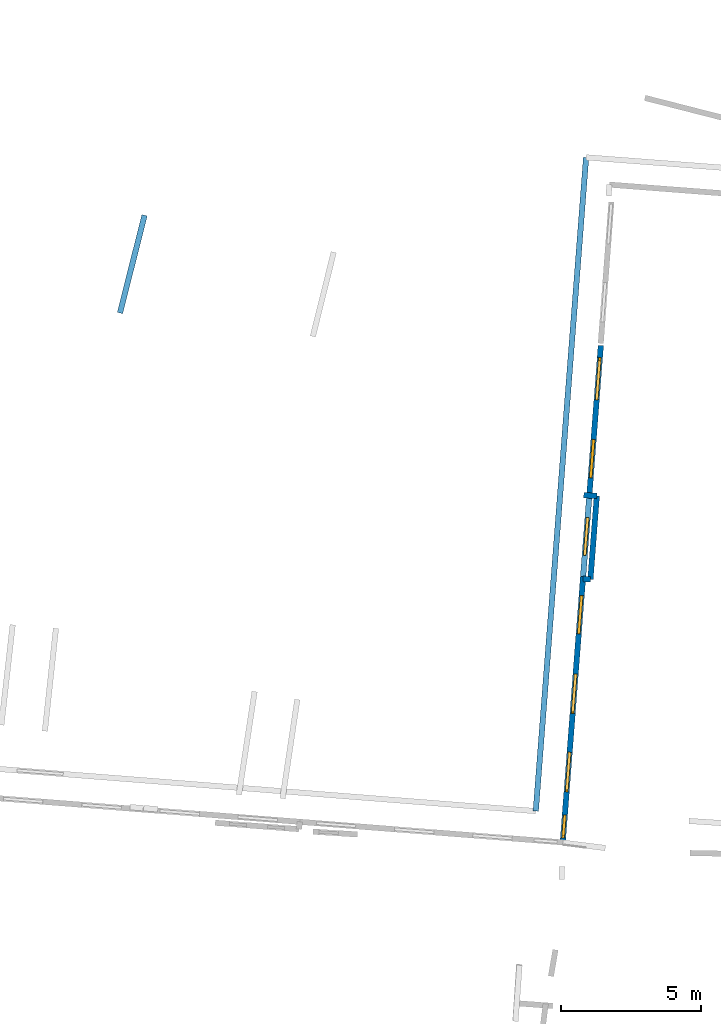
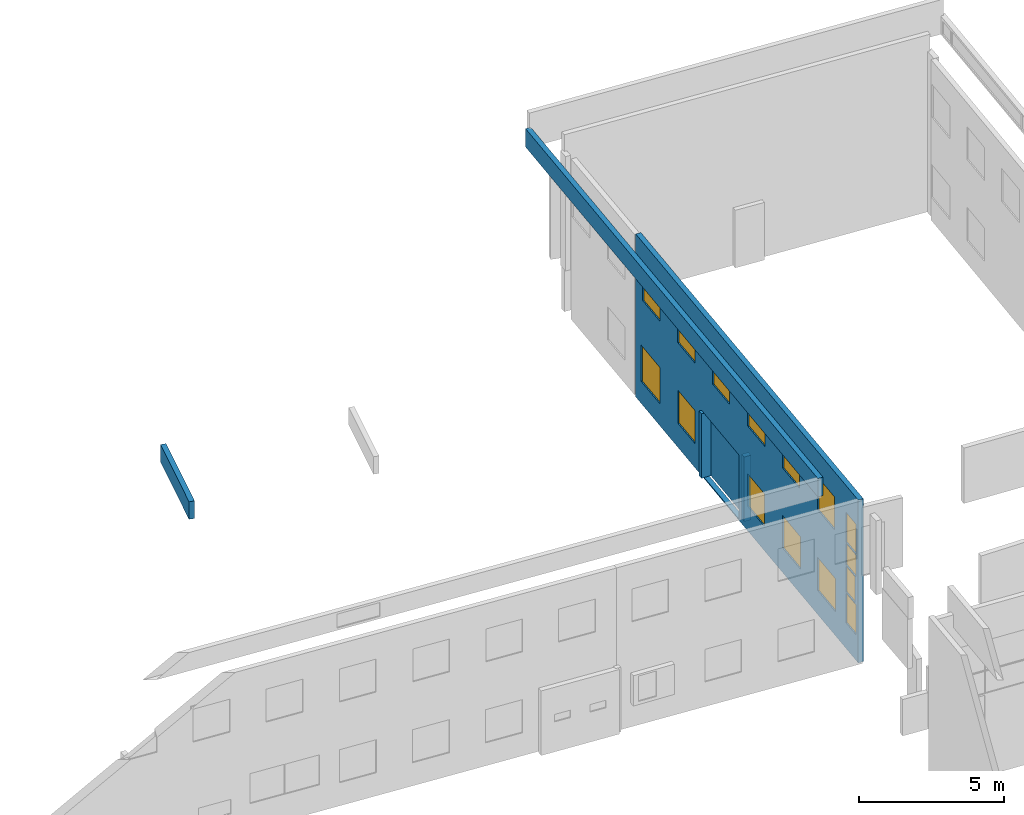
# One storey, part 22 of 27: 15 windows, 6 walls, 16 openings.
"""IFC2X3 building model written with IfcOpenShell, lengths in metres."""

from ifc_helpers import new_model, entity, si_unit, converted_unit, derived_unit, direction, frame, frame_2d, origin, origin_2d_with_axis, place, context, subcontext, project, spatial, polyline, rectangle, outline, extrude, source, transform, mapped, material, layer, layer_set, layer_usage, type_object, type_shapes, element, fill, save


model = new_model("IFC2X3")

# Units and contexts
model_context = context("Model", 3, precision=1e-05, world=origin(), true_north=direction((0.0, 1.0)))
body_context = subcontext(model_context, "Body", "Model", "MODEL_VIEW")
ifc_project = project(units=[si_unit("LENGTHUNIT", "METRE"), si_unit("AREAUNIT", "SQUARE_METRE"), si_unit("VOLUMEUNIT", "CUBIC_METRE"), converted_unit("PLANEANGLEUNIT", "DEGREE", entity("IfcRatioMeasure", 0.0174532925199433), si_unit("PLANEANGLEUNIT", "RADIAN"), dimensions=[0, 0, 0, 0, 0, 0, 0]), si_unit("MASSUNIT", "GRAM", prefix="KILO"), derived_unit("MASSDENSITYUNIT", [(si_unit("MASSUNIT", "GRAM", prefix="KILO"), 1), (si_unit("LENGTHUNIT", "METRE"), -3)]), derived_unit("MOMENTOFINERTIAUNIT", [(si_unit("LENGTHUNIT", "METRE"), 4)]), si_unit("TIMEUNIT", "SECOND"), si_unit("FREQUENCYUNIT", "HERTZ"), si_unit("THERMODYNAMICTEMPERATUREUNIT", "DEGREE_CELSIUS"), derived_unit("THERMALTRANSMITTANCEUNIT", [(si_unit("MASSUNIT", "GRAM", prefix="KILO"), 1), (si_unit("THERMODYNAMICTEMPERATUREUNIT", "KELVIN"), -1), (si_unit("TIMEUNIT", "SECOND"), -3)]), derived_unit("VOLUMETRICFLOWRATEUNIT", [(si_unit("LENGTHUNIT", "METRE"), 3), (si_unit("TIMEUNIT", "SECOND"), -1)]), si_unit("ELECTRICCURRENTUNIT", "AMPERE"), si_unit("ELECTRICVOLTAGEUNIT", "VOLT"), si_unit("POWERUNIT", "WATT"), si_unit("FORCEUNIT", "NEWTON", prefix="KILO"), si_unit("ILLUMINANCEUNIT", "LUX"), si_unit("LUMINOUSFLUXUNIT", "LUMEN"), si_unit("LUMINOUSINTENSITYUNIT", "CANDELA"), derived_unit("USERDEFINED", [(si_unit("MASSUNIT", "GRAM", prefix="KILO"), -1), (si_unit("LENGTHUNIT", "METRE"), -2), (si_unit("TIMEUNIT", "SECOND"), 3), (si_unit("LUMINOUSFLUXUNIT", "LUMEN"), 1)]), derived_unit("LINEARVELOCITYUNIT", [(si_unit("LENGTHUNIT", "METRE"), 1), (si_unit("TIMEUNIT", "SECOND"), -1)]), si_unit("PRESSUREUNIT", "PASCAL"), derived_unit("USERDEFINED", [(si_unit("LENGTHUNIT", "METRE"), -2), (si_unit("MASSUNIT", "GRAM", prefix="KILO"), 1), (si_unit("TIMEUNIT", "SECOND"), -2)]), derived_unit("LINEARFORCEUNIT", [(si_unit("MASSUNIT", "GRAM", prefix="KILO"), 1), (si_unit("LENGTHUNIT", "METRE"), 1), (si_unit("TIMEUNIT", "SECOND"), -2), (si_unit("LENGTHUNIT", "METRE"), -1)]), derived_unit("PLANARFORCEUNIT", [(si_unit("MASSUNIT", "GRAM", prefix="KILO"), 1), (si_unit("LENGTHUNIT", "METRE"), 1), (si_unit("TIMEUNIT", "SECOND"), -2), (si_unit("LENGTHUNIT", "METRE"), -2)])], contexts=[model_context])

# Site, building, storey
placement_1 = place(None, origin())
site = spatial("IfcSite", under=ifc_project, at=placement_1, CompositionType="ELEMENT")
building = spatial("IfcBuilding", under=site, at=placement_1, CompositionType="ELEMENT")
storey_placement = place(placement_1, frame((0.0, 0.0, -61.043098449707)))
storey = spatial("IfcBuildingStorey", under=building, at=storey_placement, Name="level_-61.043098", CompositionType="ELEMENT", Elevation=-61.043098449707)

# Walls
ifc_material_1 = material(Name="Default wall")
ifc_layer = layer(ifc_material_1, 0.2)
ifc_layer_set = layer_set([ifc_layer], Name="wall_thickness_0.2000")
ifc_layer_usage = layer_usage(ifc_layer_set, "AXIS2", "POSITIVE", -0.1)
wall_type = type_object("IfcWallType", Name="wall_thickness_0.2000", PredefinedType="STANDARD", material=ifc_layer_set)
wall_1_placement = place(storey_placement, frame((5.55051901657496, 6.89145809731428, 0.0), z_axis=(0.0, 0.0, 1.0), x_axis=(-0.0764744936915712, -0.997071537962356, 0.0)))
element("IfcWallStandardCase", 1, at=wall_1_placement, inside=storey, type_object=wall_type, material=ifc_layer_usage, Name="Wall:224", ObjectType="Wall", context=body_context, shape_type="SweptSolid", body=[
    extrude(outline(polyline([(2.98474913976987, -0.1), (2.98474913976987, 0.1), (0.0, 0.1), (0.0, -0.1), (2.98474913976987, -0.1)])), origin(), (0.0, 0.0, 1.0), 2.72571182250977),
])
wall_2_placement = place(storey_placement, frame((5.32226209215566, 3.91544977121613, 0.0), z_axis=(0.0, 0.0, 1.0), x_axis=(-0.997131622481555, 0.0756870361904948, 0.0)))
element("IfcWallStandardCase", 2, at=wall_2_placement, inside=storey, type_object=wall_type, material=ifc_layer_usage, Name="Wall:591", ObjectType="Wall", context=body_context, shape_type="SweptSolid", body=[
    extrude(outline(polyline([(0.268145565594101, -0.1), (0.268145565594101, 0.1), (0.0, 0.1), (0.0, -0.1), (0.268145565594101, -0.1)])), origin(), (0.0, 0.0, 1.0), 2.72571182250977),
])
placement_2 = place(placement_1, frame((0.0, 0.0, -54.4207000732422)))
wall_3_placement = place(placement_2, frame((3.37360948444382, -4.34450455838752, 0.0), z_axis=(0.0, 0.0, 1.0), x_axis=(0.0767496885314045, 0.99705039256315, 0.0)))
element("IfcWallStandardCase", 3, at=wall_3_placement, inside=storey, type_object=wall_type, material=ifc_layer_usage, Name="Wall:743", ObjectType="Wall", context=body_context, shape_type="SweptSolid", body=[
    extrude(outline(polyline([(23.3795139389043, -0.1), (23.3795139389043, 0.1), (0.0, 0.1), (0.0, -0.1), (23.3795139389043, -0.1)])), origin(), (0.0, 0.0, 1.0), 0.772296905517578),
])
placement_3 = place(placement_1, frame((0.0, 0.0, -60.9578857421875)))
wall_4_placement = place(placement_3, frame((-11.4522340122233, 13.4179110781104, 0.0), z_axis=(0.0, 0.0, 1.0), x_axis=(0.244021418068795, 0.969769842552188, 0.0)))
element("IfcWallStandardCase", 4, at=wall_4_placement, inside=storey, type_object=wall_type, material=ifc_layer_usage, Name="Wall:932", ObjectType="Wall", context=body_context, shape_type="SweptSolid", body=[
    extrude(outline(polyline([(3.59132385390913, -0.1), (3.59132385390913, 0.1), (0.0, 0.1), (0.0, -0.1), (3.59132385390913, -0.1)])), origin(), (0.0, 0.0, 1.0), 0.739894866943359),
])
wall_5_placement = place(storey_placement, frame((5.55051928604574, 6.89145879668962, 0.0), z_axis=(0.0, 0.0, 1.0), x_axis=(-0.997841850426368, 0.0656630911371277, 0.0)))
element("IfcWallStandardCase", 5, at=wall_5_placement, inside=storey, type_object=wall_type, material=ifc_layer_usage, Name="Wall:1461", ObjectType="Wall", context=body_context, shape_type="SweptSolid", body=[
    extrude(outline(polyline([(0.467316178286604, -0.1), (0.467316178286604, 0.1), (0.0, 0.1), (0.0, -0.1), (0.467316178286604, -0.1)])), origin(), (0.0, 0.0, 1.0), 2.72571182250977),
])

# Wall, openings, windows
placement_4 = place(placement_1, frame((0.0, 0.0, -61.0783157348633)))
wall_6_placement = place(placement_4, frame((5.69245260744282, 12.2572666512546, 0.0), z_axis=(0.0, 0.0, 1.0), x_axis=(-0.076392795427846, -0.997077800779217, 0.0)))
wall_6 = element("IfcWallStandardCase", 6, at=wall_6_placement, inside=storey, type_object=wall_type, material=ifc_layer_usage, Name="Wall:1689", ObjectType="Wall", context=body_context, shape_type="SweptSolid", body=[
    extrude(outline(polyline([(17.778165750979, -0.1), (17.778165750979, 0.1), (0.0, 0.1), (0.0, -0.1), (17.778165750979, -0.1)])), origin(), (0.0, 0.0, 1.0), 6.869140625),
])
opening_1_placement = place(wall_6_placement, frame((5.45000039480544, -0.1, 0.0490188598632812)))
element("IfcOpeningElement", 7, at=opening_1_placement, cuts=wall_6, Name="Opening : 2820 x 2705 : 268", ObjectType="Opening", context=body_context, shape_type="SweptSolid", body=[
    extrude(rectangle(XDim=2.82, YDim=2.705, at=frame_2d((1.3525, 1.41), x_axis=(0.0, 1.0))), frame((0.0, 0.0, 0.0), z_axis=(0.0, 1.0, 0.0), x_axis=(0.0, 0.0, 1.0)), (0.0, 0.0, 1.0), 0.2),
])
opening_2_placement = place(wall_6_placement, frame((0.545000040592521, -0.1, 4.40901947021484)))
opening_2 = element("IfcOpeningElement", 8, at=opening_2_placement, cuts=wall_6, Name="Opening : 1405 x 1395 : 269", ObjectType="Opening", context=body_context, shape_type="SweptSolid", body=[
    extrude(rectangle(XDim=1.405, YDim=1.395, at=frame_2d((0.6975, 0.7025), x_axis=(0.0, 1.0))), frame((0.0, 0.0, 0.0), z_axis=(0.0, 1.0, 0.0), x_axis=(0.0, 0.0, 1.0)), (0.0, 0.0, 1.0), 0.2),
])
opening_3_placement = place(wall_6_placement, frame((0.435350386967062, -0.1, 0.926525115966797)))
opening_3 = element("IfcOpeningElement", 9, at=opening_3_placement, cuts=wall_6, Name="Opening : 1495 x 1530 : 270", ObjectType="Opening", context=body_context, shape_type="SweptSolid", body=[
    extrude(rectangle(XDim=1.495, YDim=1.53, at=frame_2d((0.765, 0.7475), x_axis=(0.0, 1.0))), frame((0.0, 0.0, 0.0), z_axis=(0.0, 1.0, 0.0), x_axis=(0.0, 0.0, 1.0)), (0.0, 0.0, 1.0), 0.2),
])
opening_4_placement = place(wall_6_placement, frame((6.15499957571703, -0.1, 4.41402053833008)))
opening_4 = element("IfcOpeningElement", 10, at=opening_4_placement, cuts=wall_6, Name="Opening : 1355 x 1390 : 271", ObjectType="Opening", context=body_context, shape_type="SweptSolid", body=[
    extrude(rectangle(XDim=1.355, YDim=1.39, at=frame_2d((0.695, 0.6775), x_axis=(0.0, 1.0))), frame((0.0, 0.0, 0.0), z_axis=(0.0, 1.0, 0.0), x_axis=(0.0, 0.0, 1.0)), (0.0, 0.0, 1.0), 0.2),
])
opening_5_placement = place(wall_6_placement, frame((8.9500003913133, -0.1, 4.41901779174805)))
opening_5 = element("IfcOpeningElement", 11, at=opening_5_placement, cuts=wall_6, Name="Opening : 1365 x 1385 : 272", ObjectType="Opening", context=body_context, shape_type="SweptSolid", body=[
    extrude(rectangle(XDim=1.365, YDim=1.385, at=frame_2d((0.6925, 0.6825), x_axis=(0.0, 1.0))), frame((0.0, 0.0, 0.0), z_axis=(0.0, 1.0, 0.0), x_axis=(0.0, 0.0, 1.0)), (0.0, 0.0, 1.0), 0.2),
])
opening_6_placement = place(wall_6_placement, frame((14.5450012880872, -0.1, 4.41901779174805)))
opening_6 = element("IfcOpeningElement", 12, at=opening_6_placement, cuts=wall_6, Name="Opening : 1355 x 1385 : 273", ObjectType="Opening", context=body_context, shape_type="SweptSolid", body=[
    extrude(rectangle(XDim=1.355, YDim=1.385, at=frame_2d((0.6925, 0.6775), x_axis=(0.0, 1.0))), frame((0.0, 0.0, 0.0), z_axis=(0.0, 1.0, 0.0), x_axis=(0.0, 0.0, 1.0)), (0.0, 0.0, 1.0), 0.2),
])
opening_7_placement = place(wall_6_placement, frame((3.35499973226132, -0.1, 4.40901947021484)))
opening_7 = element("IfcOpeningElement", 13, at=opening_7_placement, cuts=wall_6, Name="Opening : 1380 x 1390 : 274", ObjectType="Opening", context=body_context, shape_type="SweptSolid", body=[
    extrude(rectangle(XDim=1.38, YDim=1.39, at=frame_2d((0.695, 0.69), x_axis=(0.0, 1.0))), frame((0.0, 0.0, 0.0), z_axis=(0.0, 1.0, 0.0), x_axis=(0.0, 0.0, 1.0)), (0.0, 0.0, 1.0), 0.2),
])
opening_8_placement = place(wall_6_placement, frame((11.7450007678927, -0.1, 4.40901947021484)))
opening_8 = element("IfcOpeningElement", 14, at=opening_8_placement, cuts=wall_6, Name="Opening : 1360 x 1390 : 275", ObjectType="Opening", context=body_context, shape_type="SweptSolid", body=[
    extrude(rectangle(XDim=1.36, YDim=1.39, at=frame_2d((0.695, 0.68), x_axis=(0.0, 1.0))), frame((0.0, 0.0, 0.0), z_axis=(0.0, 1.0, 0.0), x_axis=(0.0, 0.0, 1.0)), (0.0, 0.0, 1.0), 0.2),
])
opening_9_placement = place(wall_6_placement, frame((16.7899999825096, -0.1, 4.47401809692383)))
opening_9 = element("IfcOpeningElement", 15, at=opening_9_placement, cuts=wall_6, Name="Opening : 820 x 1265 : 276", ObjectType="Opening", context=body_context, shape_type="SweptSolid", body=[
    extrude(rectangle(XDim=0.82, YDim=1.265, at=frame_2d((0.6325, 0.41), x_axis=(0.0, 1.0))), frame((0.0, 0.0, 0.0), z_axis=(0.0, 1.0, 0.0), x_axis=(0.0, 0.0, 1.0)), (0.0, 0.0, 1.0), 0.2),
])
opening_10_placement = place(wall_6_placement, frame((16.7850005156333, -0.1, 3.51401901245117)))
opening_10 = element("IfcOpeningElement", 16, at=opening_10_placement, cuts=wall_6, Name="Opening : 825 x 920 : 277", ObjectType="Opening", context=body_context, shape_type="SweptSolid", body=[
    extrude(rectangle(XDim=0.825, YDim=0.92, at=frame_2d((0.46, 0.4125), x_axis=(0.0, 1.0))), frame((0.0, 0.0, 0.0), z_axis=(0.0, 1.0, 0.0), x_axis=(0.0, 0.0, 1.0)), (0.0, 0.0, 1.0), 0.2),
])
opening_11_placement = place(wall_6_placement, frame((16.7848006144863, -0.1, 2.37401962280273)))
opening_11 = element("IfcOpeningElement", 17, at=opening_11_placement, cuts=wall_6, Name="Opening : 740 x 1100 : 278", ObjectType="Opening", context=body_context, shape_type="SweptSolid", body=[
    extrude(rectangle(XDim=0.74, YDim=1.1, at=frame_2d((0.55, 0.37), x_axis=(0.0, 1.0))), frame((0.0, 0.0, 0.0), z_axis=(0.0, 1.0, 0.0), x_axis=(0.0, 0.0, 1.0)), (0.0, 0.0, 1.0), 0.2),
])
opening_12_placement = place(wall_6_placement, frame((3.36499965332825, -0.1, 1.01401901245117)))
opening_12 = element("IfcOpeningElement", 18, at=opening_12_placement, cuts=wall_6, Name="Opening : 1360 x 1395 : 279", ObjectType="Opening", context=body_context, shape_type="SweptSolid", body=[
    extrude(rectangle(XDim=1.36, YDim=1.395, at=frame_2d((0.6975, 0.68), x_axis=(0.0, 1.0))), frame((0.0, 0.0, 0.0), z_axis=(0.0, 1.0, 0.0), x_axis=(0.0, 0.0, 1.0)), (0.0, 0.0, 1.0), 0.2),
])
opening_13_placement = place(wall_6_placement, frame((8.94000003122954, -0.1, 1.02901840209961)))
opening_13 = element("IfcOpeningElement", 19, at=opening_13_placement, cuts=wall_6, Name="Opening : 1365 x 1375 : 280", ObjectType="Opening", context=body_context, shape_type="SweptSolid", body=[
    extrude(rectangle(XDim=1.365, YDim=1.375, at=frame_2d((0.6875, 0.6825), x_axis=(0.0, 1.0))), frame((0.0, 0.0, 0.0), z_axis=(0.0, 1.0, 0.0), x_axis=(0.0, 0.0, 1.0)), (0.0, 0.0, 1.0), 0.2),
])
opening_14_placement = place(wall_6_placement, frame((11.7450007678927, -0.1, 1.03902053833008)))
opening_14 = element("IfcOpeningElement", 20, at=opening_14_placement, cuts=wall_6, Name="Opening : 1410 x 1365 : 281", ObjectType="Opening", context=body_context, shape_type="SweptSolid", body=[
    extrude(rectangle(XDim=1.41, YDim=1.365, at=frame_2d((0.6825, 0.705), x_axis=(0.0, 1.0))), frame((0.0, 0.0, 0.0), z_axis=(0.0, 1.0, 0.0), x_axis=(0.0, 0.0, 1.0)), (0.0, 0.0, 1.0), 0.2),
])
opening_15_placement = place(wall_6_placement, frame((14.5450012880872, -0.1, 1.01401901245117)))
opening_15 = element("IfcOpeningElement", 21, at=opening_15_placement, cuts=wall_6, Name="Opening : 1415 x 1390 : 282", ObjectType="Opening", context=body_context, shape_type="SweptSolid", body=[
    extrude(rectangle(XDim=1.415, YDim=1.39, at=frame_2d((0.695, 0.7075), x_axis=(0.0, 1.0))), frame((0.0, 0.0, 0.0), z_axis=(0.0, 1.0, 0.0), x_axis=(0.0, 0.0, 1.0)), (0.0, 0.0, 1.0), 0.2),
])
opening_16_placement = place(wall_6_placement, frame((16.7899999825096, -0.1, 1.07901763916016)))
opening_16 = element("IfcOpeningElement", 22, at=opening_16_placement, cuts=wall_6, Name="Opening : 820 x 1255 : 283", ObjectType="Opening", context=body_context, shape_type="SweptSolid", body=[
    extrude(rectangle(XDim=0.82, YDim=1.255, at=frame_2d((0.6275, 0.41), x_axis=(0.0, 1.0))), frame((0.0, 0.0, 0.0), z_axis=(0.0, 1.0, 0.0), x_axis=(0.0, 0.0, 1.0)), (0.0, 0.0, 1.0), 0.2),
])
ifc_material_2 = material(Name="Window Default")
window_style_1 = type_object("IfcWindowStyle", Name="Window : 1405 x 1395mm", ConstructionType="NOTDEFINED", OperationType="NOTDEFINED", ParameterTakesPrecedence=False, Sizeable=False, material=ifc_material_2)
shared_shape_1 = source(origin(), body_context, "Body", "SweptSolid", [
    extrude(rectangle(XDim=0.1, YDim=1.405, at=origin_2d_with_axis()), frame((0.7025, 0.1, 0.0), z_axis=(0.0, 0.0, 1.0), x_axis=(0.0, 1.0, 0.0)), (0.0, 0.0, 1.0), 1.395),
])
type_shapes(window_style_1, [shared_shape_1])
window_1_placement = place(opening_2_placement, origin())
window_1 = element("IfcWindow", 23, at=window_1_placement, inside=storey, type_object=window_style_1, Name="Window : 1405 x 1395mm : 251", ObjectType="Window : 1405 x 1395mm", OverallHeight=1.395, OverallWidth=1.405, context=body_context, shape_type="MappedRepresentation", body=[
    mapped(shared_shape_1, transform((0.0, 0.0, 0.0), scale=1.0)),
])
fill(opening_2, window_1)
window_style_2 = type_object("IfcWindowStyle", Name="Window : 1415 x 1390mm", ConstructionType="NOTDEFINED", OperationType="NOTDEFINED", ParameterTakesPrecedence=False, Sizeable=False, material=ifc_material_2)
shared_shape_2 = source(origin(), body_context, "Body", "SweptSolid", [
    extrude(rectangle(XDim=0.1, YDim=1.415, at=origin_2d_with_axis()), frame((0.7075, 0.1, 0.0), z_axis=(0.0, 0.0, 1.0), x_axis=(0.0, 1.0, 0.0)), (0.0, 0.0, 1.0), 1.39),
])
type_shapes(window_style_2, [shared_shape_2])
window_2_placement = place(opening_15_placement, origin())
window_2 = element("IfcWindow", 24, at=window_2_placement, inside=storey, type_object=window_style_2, Name="Window : 1415 x 1390mm : 264", ObjectType="Window : 1415 x 1390mm", OverallHeight=1.39, OverallWidth=1.415, context=body_context, shape_type="MappedRepresentation", body=[
    mapped(shared_shape_2, transform((0.0, 0.0, 0.0), scale=1.0)),
])
fill(opening_15, window_2)
window_style_3 = type_object("IfcWindowStyle", Name="Window : 1410 x 1365mm", ConstructionType="NOTDEFINED", OperationType="NOTDEFINED", ParameterTakesPrecedence=False, Sizeable=False, material=ifc_material_2)
shared_shape_3 = source(origin(), body_context, "Body", "SweptSolid", [
    extrude(rectangle(XDim=0.1, YDim=1.41, at=origin_2d_with_axis()), frame((0.705, 0.1, 0.0), z_axis=(0.0, 0.0, 1.0), x_axis=(0.0, 1.0, 0.0)), (0.0, 0.0, 1.0), 1.365),
])
type_shapes(window_style_3, [shared_shape_3])
window_3_placement = place(opening_14_placement, origin())
window_3 = element("IfcWindow", 25, at=window_3_placement, inside=storey, type_object=window_style_3, Name="Window : 1410 x 1365mm : 263", ObjectType="Window : 1410 x 1365mm", OverallHeight=1.365, OverallWidth=1.41, context=body_context, shape_type="MappedRepresentation", body=[
    mapped(shared_shape_3, transform((0.0, 0.0, 0.0), scale=1.0)),
])
fill(opening_14, window_3)
window_style_4 = type_object("IfcWindowStyle", Name="Window : 1495 x 1530mm", ConstructionType="NOTDEFINED", OperationType="NOTDEFINED", ParameterTakesPrecedence=False, Sizeable=False, material=ifc_material_2)
shared_shape_4 = source(origin(), body_context, "Body", "SweptSolid", [
    extrude(rectangle(XDim=0.1, YDim=1.495, at=origin_2d_with_axis()), frame((0.7475, 0.1, 0.0), z_axis=(0.0, 0.0, 1.0), x_axis=(0.0, 1.0, 0.0)), (0.0, 0.0, 1.0), 1.53),
])
type_shapes(window_style_4, [shared_shape_4])
window_4_placement = place(opening_3_placement, origin())
window_4 = element("IfcWindow", 26, at=window_4_placement, inside=storey, type_object=window_style_4, Name="Window : 1495 x 1530mm : 252", ObjectType="Window : 1495 x 1530mm", OverallHeight=1.53, OverallWidth=1.495, context=body_context, shape_type="MappedRepresentation", body=[
    mapped(shared_shape_4, transform((0.0, 0.0, 0.0), scale=1.0)),
])
fill(opening_3, window_4)
window_style_5 = type_object("IfcWindowStyle", Name="Window : 1355 x 1390mm", ConstructionType="NOTDEFINED", OperationType="NOTDEFINED", ParameterTakesPrecedence=False, Sizeable=False, material=ifc_material_2)
shared_shape_5 = source(origin(), body_context, "Body", "SweptSolid", [
    extrude(rectangle(XDim=0.1, YDim=1.355, at=origin_2d_with_axis()), frame((0.6775, 0.1, 0.0), z_axis=(0.0, 0.0, 1.0), x_axis=(0.0, 1.0, 0.0)), (0.0, 0.0, 1.0), 1.39),
])
type_shapes(window_style_5, [shared_shape_5])
window_5_placement = place(opening_4_placement, origin())
window_5 = element("IfcWindow", 27, at=window_5_placement, inside=storey, type_object=window_style_5, Name="Window : 1355 x 1390mm : 253", ObjectType="Window : 1355 x 1390mm", OverallHeight=1.39, OverallWidth=1.355, context=body_context, shape_type="MappedRepresentation", body=[
    mapped(shared_shape_5, transform((0.0, 0.0, 0.0), scale=1.0)),
])
fill(opening_4, window_5)
window_style_6 = type_object("IfcWindowStyle", Name="Window : 1365 x 1385mm", ConstructionType="NOTDEFINED", OperationType="NOTDEFINED", ParameterTakesPrecedence=False, Sizeable=False, material=ifc_material_2)
shared_shape_6 = source(origin(), body_context, "Body", "SweptSolid", [
    extrude(rectangle(XDim=0.1, YDim=1.365, at=origin_2d_with_axis()), frame((0.6825, 0.1, 0.0), z_axis=(0.0, 0.0, 1.0), x_axis=(0.0, 1.0, 0.0)), (0.0, 0.0, 1.0), 1.385),
])
type_shapes(window_style_6, [shared_shape_6])
window_6_placement = place(opening_5_placement, origin())
window_6 = element("IfcWindow", 28, at=window_6_placement, inside=storey, type_object=window_style_6, Name="Window : 1365 x 1385mm : 254", ObjectType="Window : 1365 x 1385mm", OverallHeight=1.385, OverallWidth=1.365, context=body_context, shape_type="MappedRepresentation", body=[
    mapped(shared_shape_6, transform((0.0, 0.0, 0.0), scale=1.0)),
])
fill(opening_5, window_6)
window_style_7 = type_object("IfcWindowStyle", Name="Window : 1355 x 1385mm", ConstructionType="NOTDEFINED", OperationType="NOTDEFINED", ParameterTakesPrecedence=False, Sizeable=False, material=ifc_material_2)
shared_shape_7 = source(origin(), body_context, "Body", "SweptSolid", [
    extrude(rectangle(XDim=0.1, YDim=1.355, at=origin_2d_with_axis()), frame((0.6775, 0.1, 0.0), z_axis=(0.0, 0.0, 1.0), x_axis=(0.0, 1.0, 0.0)), (0.0, 0.0, 1.0), 1.385),
])
type_shapes(window_style_7, [shared_shape_7])
window_7_placement = place(opening_6_placement, origin())
window_7 = element("IfcWindow", 29, at=window_7_placement, inside=storey, type_object=window_style_7, Name="Window : 1355 x 1385mm : 255", ObjectType="Window : 1355 x 1385mm", OverallHeight=1.385, OverallWidth=1.355, context=body_context, shape_type="MappedRepresentation", body=[
    mapped(shared_shape_7, transform((0.0, 0.0, 0.0), scale=1.0)),
])
fill(opening_6, window_7)
window_style_8 = type_object("IfcWindowStyle", Name="Window : 1380 x 1390mm", ConstructionType="NOTDEFINED", OperationType="NOTDEFINED", ParameterTakesPrecedence=False, Sizeable=False, material=ifc_material_2)
shared_shape_8 = source(origin(), body_context, "Body", "SweptSolid", [
    extrude(rectangle(XDim=0.1, YDim=1.38, at=origin_2d_with_axis()), frame((0.69, 0.1, 0.0), z_axis=(0.0, 0.0, 1.0), x_axis=(0.0, 1.0, 0.0)), (0.0, 0.0, 1.0), 1.39),
])
type_shapes(window_style_8, [shared_shape_8])
window_8_placement = place(opening_7_placement, origin())
window_8 = element("IfcWindow", 30, at=window_8_placement, inside=storey, type_object=window_style_8, Name="Window : 1380 x 1390mm : 256", ObjectType="Window : 1380 x 1390mm", OverallHeight=1.39, OverallWidth=1.38, context=body_context, shape_type="MappedRepresentation", body=[
    mapped(shared_shape_8, transform((0.0, 0.0, 0.0), scale=1.0)),
])
fill(opening_7, window_8)
window_style_9 = type_object("IfcWindowStyle", Name="Window : 1360 x 1390mm", ConstructionType="NOTDEFINED", OperationType="NOTDEFINED", ParameterTakesPrecedence=False, Sizeable=False, material=ifc_material_2)
shared_shape_9 = source(origin(), body_context, "Body", "SweptSolid", [
    extrude(rectangle(XDim=0.1, YDim=1.36, at=origin_2d_with_axis()), frame((0.68, 0.1, 0.0), z_axis=(0.0, 0.0, 1.0), x_axis=(0.0, 1.0, 0.0)), (0.0, 0.0, 1.0), 1.39),
])
type_shapes(window_style_9, [shared_shape_9])
window_9_placement = place(opening_8_placement, origin())
window_9 = element("IfcWindow", 31, at=window_9_placement, inside=storey, type_object=window_style_9, Name="Window : 1360 x 1390mm : 257", ObjectType="Window : 1360 x 1390mm", OverallHeight=1.39, OverallWidth=1.36, context=body_context, shape_type="MappedRepresentation", body=[
    mapped(shared_shape_9, transform((0.0, 0.0, 0.0), scale=1.0)),
])
fill(opening_8, window_9)
window_style_10 = type_object("IfcWindowStyle", Name="Window : 820 x 1265mm", ConstructionType="NOTDEFINED", OperationType="NOTDEFINED", ParameterTakesPrecedence=False, Sizeable=False, material=ifc_material_2)
shared_shape_10 = source(origin(), body_context, "Body", "SweptSolid", [
    extrude(rectangle(XDim=0.1, YDim=0.82, at=origin_2d_with_axis()), frame((0.41, 0.1, 0.0), z_axis=(0.0, 0.0, 1.0), x_axis=(0.0, 1.0, 0.0)), (0.0, 0.0, 1.0), 1.265),
])
type_shapes(window_style_10, [shared_shape_10])
window_10_placement = place(opening_9_placement, origin())
window_10 = element("IfcWindow", 32, at=window_10_placement, inside=storey, type_object=window_style_10, Name="Window : 820 x 1265mm : 258", ObjectType="Window : 820 x 1265mm", OverallHeight=1.265, OverallWidth=0.82, context=body_context, shape_type="MappedRepresentation", body=[
    mapped(shared_shape_10, transform((0.0, 0.0, 0.0), scale=1.0)),
])
fill(opening_9, window_10)
window_style_11 = type_object("IfcWindowStyle", Name="Window : 825 x 920mm", ConstructionType="NOTDEFINED", OperationType="NOTDEFINED", ParameterTakesPrecedence=False, Sizeable=False, material=ifc_material_2)
shared_shape_11 = source(origin(), body_context, "Body", "SweptSolid", [
    extrude(rectangle(XDim=0.1, YDim=0.825, at=origin_2d_with_axis()), frame((0.4125, 0.1, 0.0), z_axis=(0.0, 0.0, 1.0), x_axis=(0.0, 1.0, 0.0)), (0.0, 0.0, 1.0), 0.92),
])
type_shapes(window_style_11, [shared_shape_11])
window_11_placement = place(opening_10_placement, origin())
window_11 = element("IfcWindow", 33, at=window_11_placement, inside=storey, type_object=window_style_11, Name="Window : 825 x 920mm : 259", ObjectType="Window : 825 x 920mm", OverallHeight=0.92, OverallWidth=0.825, context=body_context, shape_type="MappedRepresentation", body=[
    mapped(shared_shape_11, transform((0.0, 0.0, 0.0), scale=1.0)),
])
fill(opening_10, window_11)
window_style_12 = type_object("IfcWindowStyle", Name="Window : 740 x 1100mm", ConstructionType="NOTDEFINED", OperationType="NOTDEFINED", ParameterTakesPrecedence=False, Sizeable=False, material=ifc_material_2)
shared_shape_12 = source(origin(), body_context, "Body", "SweptSolid", [
    extrude(rectangle(XDim=0.1, YDim=0.74, at=origin_2d_with_axis()), frame((0.37, 0.1, 0.0), z_axis=(0.0, 0.0, 1.0), x_axis=(0.0, 1.0, 0.0)), (0.0, 0.0, 1.0), 1.1),
])
type_shapes(window_style_12, [shared_shape_12])
window_12_placement = place(opening_11_placement, origin())
window_12 = element("IfcWindow", 34, at=window_12_placement, inside=storey, type_object=window_style_12, Name="Window : 740 x 1100mm : 260", ObjectType="Window : 740 x 1100mm", OverallHeight=1.1, OverallWidth=0.74, context=body_context, shape_type="MappedRepresentation", body=[
    mapped(shared_shape_12, transform((0.0, 0.0, 0.0), scale=1.0)),
])
fill(opening_11, window_12)
window_style_13 = type_object("IfcWindowStyle", Name="Window : 1360 x 1395mm", ConstructionType="NOTDEFINED", OperationType="NOTDEFINED", ParameterTakesPrecedence=False, Sizeable=False, material=ifc_material_2)
shared_shape_13 = source(origin(), body_context, "Body", "SweptSolid", [
    extrude(rectangle(XDim=0.1, YDim=1.36, at=origin_2d_with_axis()), frame((0.68, 0.1, 0.0), z_axis=(0.0, 0.0, 1.0), x_axis=(0.0, 1.0, 0.0)), (0.0, 0.0, 1.0), 1.395),
])
type_shapes(window_style_13, [shared_shape_13])
window_13_placement = place(opening_12_placement, origin())
window_13 = element("IfcWindow", 35, at=window_13_placement, inside=storey, type_object=window_style_13, Name="Window : 1360 x 1395mm : 261", ObjectType="Window : 1360 x 1395mm", OverallHeight=1.395, OverallWidth=1.36, context=body_context, shape_type="MappedRepresentation", body=[
    mapped(shared_shape_13, transform((0.0, 0.0, 0.0), scale=1.0)),
])
fill(opening_12, window_13)
window_style_14 = type_object("IfcWindowStyle", Name="Window : 1365 x 1375mm", ConstructionType="NOTDEFINED", OperationType="NOTDEFINED", ParameterTakesPrecedence=False, Sizeable=False, material=ifc_material_2)
shared_shape_14 = source(origin(), body_context, "Body", "SweptSolid", [
    extrude(rectangle(XDim=0.1, YDim=1.365, at=origin_2d_with_axis()), frame((0.6825, 0.1, 0.0), z_axis=(0.0, 0.0, 1.0), x_axis=(0.0, 1.0, 0.0)), (0.0, 0.0, 1.0), 1.375),
])
type_shapes(window_style_14, [shared_shape_14])
window_14_placement = place(opening_13_placement, origin())
window_14 = element("IfcWindow", 36, at=window_14_placement, inside=storey, type_object=window_style_14, Name="Window : 1365 x 1375mm : 262", ObjectType="Window : 1365 x 1375mm", OverallHeight=1.375, OverallWidth=1.365, context=body_context, shape_type="MappedRepresentation", body=[
    mapped(shared_shape_14, transform((0.0, 0.0, 0.0), scale=1.0)),
])
fill(opening_13, window_14)
window_style_15 = type_object("IfcWindowStyle", Name="Window : 820 x 1255mm", ConstructionType="NOTDEFINED", OperationType="NOTDEFINED", ParameterTakesPrecedence=False, Sizeable=False, material=ifc_material_2)
shared_shape_15 = source(origin(), body_context, "Body", "SweptSolid", [
    extrude(rectangle(XDim=0.1, YDim=0.82, at=origin_2d_with_axis()), frame((0.41, 0.1, 0.0), z_axis=(0.0, 0.0, 1.0), x_axis=(0.0, 1.0, 0.0)), (0.0, 0.0, 1.0), 1.255),
])
type_shapes(window_style_15, [shared_shape_15])
window_15_placement = place(opening_16_placement, origin())
window_15 = element("IfcWindow", 37, at=window_15_placement, inside=storey, type_object=window_style_15, Name="Window : 820 x 1255mm : 265", ObjectType="Window : 820 x 1255mm", OverallHeight=1.255, OverallWidth=0.82, context=body_context, shape_type="MappedRepresentation", body=[
    mapped(shared_shape_15, transform((0.0, 0.0, 0.0), scale=1.0)),
])
fill(opening_16, window_15)

save(model, "model.ifc")
